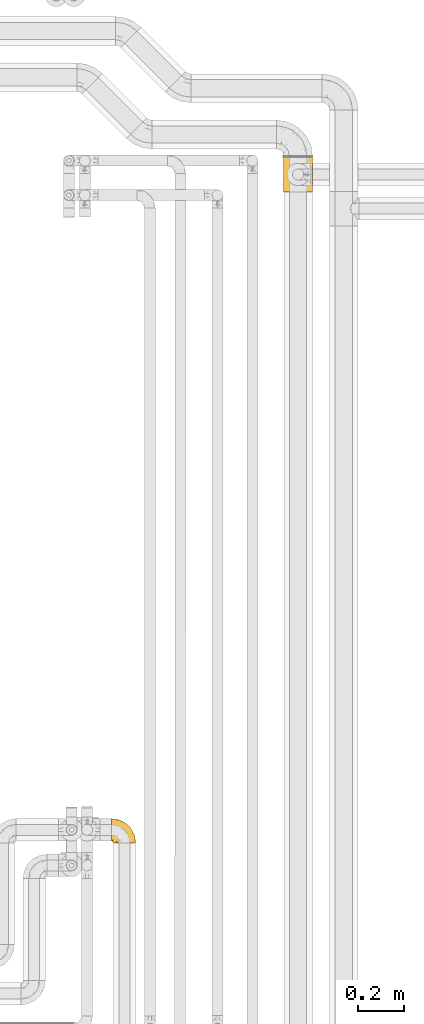
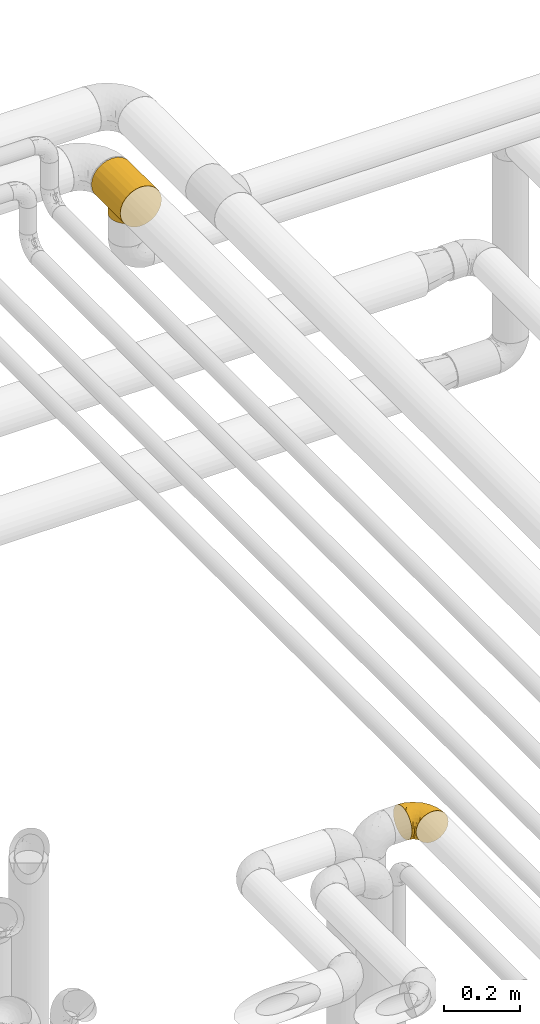
# One storey, part 403 of 827: 2 coverings.
"""IFC2X3 building model written with IfcOpenShell, lengths in millimetres."""

from ifc_helpers import new_model, entity, si_unit, converted_unit, derived_unit, direction, frame, origin, place, context, subcontext, project, spatial, faceted_brep, element, save


model = new_model("IFC2X3")

# Units and contexts
model_context = context("Model", 3, precision=0.01, world=origin(), true_north=direction((6.12303176911189e-17, 1.0)))
body_context = subcontext(model_context, "Body", "Model", "MODEL_VIEW")
ifc_project = project(units=[si_unit("LENGTHUNIT", "METRE", prefix="MILLI"), si_unit("AREAUNIT", "SQUARE_METRE"), si_unit("VOLUMEUNIT", "CUBIC_METRE"), converted_unit("PLANEANGLEUNIT", "DEGREE", entity("IfcRatioMeasure", 0.0174532925199433), si_unit("PLANEANGLEUNIT", "RADIAN"), dimensions=[0, 0, 0, 0, 0, 0, 0]), si_unit("MASSUNIT", "GRAM", prefix="KILO"), derived_unit("MASSDENSITYUNIT", [(si_unit("MASSUNIT", "GRAM", prefix="KILO"), 1), (si_unit("LENGTHUNIT", "METRE"), -3)]), derived_unit("MOMENTOFINERTIAUNIT", [(si_unit("LENGTHUNIT", "METRE"), 4)]), si_unit("TIMEUNIT", "SECOND"), si_unit("FREQUENCYUNIT", "HERTZ"), si_unit("THERMODYNAMICTEMPERATUREUNIT", "DEGREE_CELSIUS"), derived_unit("THERMALTRANSMITTANCEUNIT", [(si_unit("MASSUNIT", "GRAM", prefix="KILO"), 1), (si_unit("THERMODYNAMICTEMPERATUREUNIT", "KELVIN"), -1), (si_unit("TIMEUNIT", "SECOND"), -3)]), derived_unit("VOLUMETRICFLOWRATEUNIT", [(si_unit("LENGTHUNIT", "METRE"), 3), (si_unit("TIMEUNIT", "SECOND"), -1)]), derived_unit("MASSFLOWRATEUNIT", [(si_unit("MASSUNIT", "GRAM", prefix="KILO"), 1), (si_unit("TIMEUNIT", "SECOND"), -1)]), derived_unit("ROTATIONALFREQUENCYUNIT", [(si_unit("TIMEUNIT", "SECOND"), -1)]), si_unit("ELECTRICCURRENTUNIT", "AMPERE"), si_unit("ELECTRICVOLTAGEUNIT", "VOLT"), si_unit("POWERUNIT", "WATT"), si_unit("FORCEUNIT", "NEWTON", prefix="KILO"), si_unit("ILLUMINANCEUNIT", "LUX"), si_unit("LUMINOUSFLUXUNIT", "LUMEN"), si_unit("LUMINOUSINTENSITYUNIT", "CANDELA"), derived_unit("USERDEFINED", [(si_unit("MASSUNIT", "GRAM", prefix="KILO"), -1), (si_unit("LENGTHUNIT", "METRE"), -2), (si_unit("TIMEUNIT", "SECOND"), 3), (si_unit("LUMINOUSFLUXUNIT", "LUMEN"), 1)]), derived_unit("LINEARVELOCITYUNIT", [(si_unit("LENGTHUNIT", "METRE"), 1), (si_unit("TIMEUNIT", "SECOND"), -1)]), si_unit("PRESSUREUNIT", "PASCAL"), derived_unit("USERDEFINED", [(si_unit("LENGTHUNIT", "METRE"), -2), (si_unit("MASSUNIT", "GRAM", prefix="KILO"), 1), (si_unit("TIMEUNIT", "SECOND"), -2)]), derived_unit("LINEARFORCEUNIT", [(si_unit("MASSUNIT", "GRAM", prefix="KILO"), 1), (si_unit("LENGTHUNIT", "METRE"), 1), (si_unit("TIMEUNIT", "SECOND"), -2), (si_unit("LENGTHUNIT", "METRE"), -1)]), derived_unit("PLANARFORCEUNIT", [(si_unit("MASSUNIT", "GRAM", prefix="KILO"), 1), (si_unit("LENGTHUNIT", "METRE"), 1), (si_unit("TIMEUNIT", "SECOND"), -2), (si_unit("LENGTHUNIT", "METRE"), -2)])], contexts=[model_context])

# Site, building, storey
site_placement = place(None, origin())
site = spatial("IfcSite", under=ifc_project, at=site_placement, CompositionType="ELEMENT")
building_placement = place(site_placement, origin())
building = spatial("IfcBuilding", under=site, at=building_placement, CompositionType="ELEMENT")
storey_placement = place(building_placement, frame((0.0, 0.0, 28200.0)))
storey = spatial("IfcBuildingStorey", under=building, at=storey_placement, Name="08", CompositionType="ELEMENT", Elevation=28200.0)

# Coverings
covering_1_placement = place(storey_placement, frame((47825.42, 15248.43, 2949.25)))
element("IfcCovering", 1, at=covering_1_placement, inside=storey, Name=":ADSK_", ObjectType=":ADSK_", PredefinedType="INSULATION", context=body_context, shape_type="Brep", body=[
    faceted_brep([(1.6, 58.6, 99.9), (1.6, 69.54, 98.66), (1.6, 79.93, 95.02), (1.6, 89.25, 89.17), (1.6, 97.03, 81.38), (1.6, 102.88, 72.06), (1.6, 106.51, 61.68), (1.6, 107.75, 50.75), (1.6, 106.51, 39.8), (1.6, 102.87, 29.41), (1.6, 97.02, 20.09), (1.6, 89.23, 12.31), (1.6, 79.91, 6.46), (1.6, 69.53, 2.83), (1.6, 58.6, 1.6), (1.6, 52.89, 2.24), (1.6, 47.65, 2.83), (1.6, 42.46, 4.65), (1.6, 37.26, 6.47), (1.6, 27.94, 12.32), (1.6, 20.16, 20.11), (1.6, 14.31, 29.43), (1.6, 10.68, 39.81), (1.6, 9.45, 50.75), (1.6, 10.68, 61.69), (1.6, 14.32, 72.08), (1.6, 20.17, 81.4), (1.6, 27.96, 89.18), (1.6, 37.28, 95.03), (1.6, 42.47, 96.85), (1.6, 47.66, 98.66), (1.6, 52.89, 99.25), (1.6, 55.75, 99.57), (11.12, 1.6, 38.02), (16.03, 1.6, 26.17), (19.94, 1.6, 21.08), (23.84, 1.6, 15.99), (28.93, 1.6, 12.09), (34.02, 1.6, 8.18), (39.95, 1.6, 5.73), (45.87, 1.6, 3.27), (52.86, 1.6, 2.35), (55.73, 1.6, 1.97), (58.6, 1.6, 1.6), (71.32, 1.6, 3.27), (83.17, 1.6, 8.18), (93.35, 1.6, 15.99), (101.16, 1.6, 26.17), (106.07, 1.6, 38.02), (107.75, 1.6, 50.75), (106.07, 1.6, 63.47), (101.16, 1.6, 75.32), (93.35, 1.6, 85.5), (83.17, 1.6, 93.31), (71.32, 1.6, 98.22), (58.6, 1.6, 99.9), (52.86, 1.6, 99.14), (45.87, 1.6, 98.22), (39.95, 1.6, 95.77), (34.02, 1.6, 93.31), (28.93, 1.6, 89.4), (23.84, 1.6, 85.5), (19.94, 1.6, 80.41), (16.03, 1.6, 75.32), (11.12, 1.6, 63.47), (9.45, 1.6, 50.75), (81.82, 69.96, 59.31), (84.02, 59.59, 73.08), (93.05, 51.96, 63.72), (102.55, 34.4, 50.75), (104.83, 23.37, 58.64), (105.83, 13.68, 50.75), (91.87, 41.52, 76.74), (101.74, 26.26, 67.68), (97.07, 20.18, 78.92), (38.45, 72.33, 94.31), (22.17, 65.88, 98.76), (42.04, 57.55, 98.4), (77.69, 23.76, 94.57), (75.76, 46.5, 89.91), (62.11, 46.57, 96.32), (66.08, 21.17, 98.79), (54.26, 23.41, 99.9), (55.35, 17.92, 99.9), (56.44, 12.43, 99.9), (56.98, 9.72, 99.9), (57.52, 7.01, 99.9), (87.84, 26.77, 87.31), (19.41, 76.59, 95.61), (48.89, 95.55, 60.43), (26.34, 102.57, 65.24), (44.55, 92.89, 72.87), (23.41, 54.26, 99.9), (28.03, 51.17, 99.9), (32.65, 48.08, 99.9), (37.28, 44.99, 99.9), (41.9, 41.9, 99.9), (20.6, 85.16, 90.65), (63.36, 85.97, 63.14), (62.21, 59.58, 91.89), (19.94, 99.5, 75.25), (13.68, 105.83, 50.75), (80.85, 53.59, 82.18), (66.53, 67.0, 85.08), (71.06, 71.56, 76.93), (63.99, 87.47, 50.75), (75.73, 75.73, 50.75), (26.77, 92.24, 83.02), (4.31, 58.06, 99.9), (7.01, 57.52, 99.9), (12.43, 56.44, 99.9), (17.92, 55.35, 99.9), (43.43, 81.33, 87.13), (56.23, 80.35, 80.85), (54.97, 39.44, 99.17), (34.4, 102.55, 50.75), (44.99, 37.28, 99.9), (48.08, 32.65, 99.9), (51.17, 28.03, 99.9), (87.47, 63.99, 50.75), (74.55, 74.55, 67.61), (60.86, 83.62, 72.25), (49.19, 95.01, 50.75), (95.01, 49.19, 50.75), (10.27, 46.96, 98.69), (48.79, 8.77, 99.01), (45.16, 18.28, 98.79), (44.99, 11.68, 98.29), (6.17, 11.79, 68.51), (7.65, 15.69, 76.82), (21.59, 42.49, 98.54), (19.96, 47.41, 99.3), (21.0, 7.94, 83.57), (27.2, 9.27, 89.47), (14.83, 7.98, 75.76), (19.7, 13.4, 84.86), (10.93, 13.04, 75.89), (9.63, 7.36, 64.77), (19.97, 23.46, 90.83), (21.13, 30.46, 94.62), (14.14, 26.54, 90.37), (30.2, 6.76, 91.18), (8.12, 26.46, 88.65), (9.93, 20.77, 84.11), (24.62, 20.68, 91.75), (11.87, 40.26, 96.86), (7.15, 7.15, 50.75), (5.32, 9.28, 58.97), (26.68, 38.78, 98.37), (13.92, 18.27, 83.91), (30.67, 31.78, 97.52), (36.65, 12.75, 95.55), (42.89, 22.96, 98.76), (34.04, 17.55, 95.26), (36.6, 27.63, 98.04), (26.41, 15.23, 90.65), (10.07, 33.25, 93.51), (15.83, 32.43, 94.16), (41.99, 27.9, 99.1), (14.83, 7.97, 25.73), (26.4, 15.22, 10.84), (21.01, 7.93, 17.92), (19.71, 13.38, 16.64), (5.72, 13.12, 30.44), (21.6, 42.49, 2.95), (19.96, 47.4, 2.19), (28.03, 51.17, 1.6), (11.87, 40.24, 4.63), (9.93, 20.76, 17.39), (58.06, 4.31, 1.6), (56.44, 12.43, 1.6), (57.52, 7.01, 1.6), (8.13, 26.44, 12.86), (14.15, 26.52, 11.13), (44.99, 11.68, 3.2), (36.65, 12.75, 5.94), (30.2, 6.76, 10.31), (10.06, 33.21, 8.0), (15.83, 32.41, 7.34), (48.79, 8.77, 2.48), (42.89, 22.96, 2.73), (45.38, 18.48, 2.64), (12.43, 56.44, 1.6), (10.28, 46.95, 2.8), (9.64, 7.36, 36.71), (55.35, 17.92, 1.6), (54.26, 23.41, 1.6), (6.05, 9.85, 38.59), (7.01, 57.52, 1.6), (9.72, 56.98, 1.6), (32.65, 48.08, 1.6), (26.68, 38.78, 3.12), (13.92, 18.25, 17.59), (37.28, 44.99, 1.6), (30.66, 31.74, 3.98), (21.14, 30.45, 6.87), (36.59, 27.63, 3.45), (24.6, 20.65, 9.76), (17.92, 55.35, 1.6), (23.41, 54.26, 1.6), (10.93, 13.03, 25.62), (19.97, 23.44, 10.67), (41.99, 27.9, 2.39), (48.08, 32.65, 1.6), (34.04, 17.55, 6.23), (27.21, 9.27, 12.02), (51.17, 28.03, 1.6), (44.99, 37.28, 1.6), (41.9, 41.9, 1.6), (55.26, 39.74, 2.4), (104.83, 23.37, 42.85), (87.84, 26.77, 14.18), (75.91, 46.18, 11.56), (80.84, 53.54, 19.27), (91.87, 41.53, 24.75), (83.98, 59.61, 28.37), (19.16, 76.79, 5.95), (22.37, 66.11, 2.79), (66.08, 21.17, 2.71), (93.05, 51.96, 37.78), (101.74, 26.26, 33.81), (97.07, 20.18, 22.57), (77.69, 23.76, 6.92), (44.55, 92.88, 28.61), (26.34, 102.57, 36.24), (48.9, 95.54, 41.05), (70.99, 71.63, 24.55), (74.55, 74.55, 33.88), (37.8, 72.51, 7.11), (81.82, 69.96, 42.18), (26.77, 92.23, 18.46), (20.6, 85.15, 10.84), (56.15, 80.45, 20.69), (60.85, 83.65, 29.27), (42.06, 57.57, 3.1), (57.03, 63.68, 9.18), (63.4, 85.95, 38.38), (19.94, 99.49, 26.23), (43.59, 81.23, 14.34), (62.61, 47.07, 5.46), (66.52, 66.99, 16.39)], [[[0, 1, 2, 3, 4, 5, 6, 7, 8, 9, 10, 11, 12, 13, 14, 15, 16, 17, 18, 19, 20, 21, 22, 23, 24, 25, 26, 27, 28, 29, 30, 31, 32]], [[33, 34, 35, 36, 37, 38, 39, 40, 41, 42, 43, 44, 45, 46, 47, 48, 49, 50, 51, 52, 53, 54, 55, 56, 57, 58, 59, 60, 61, 62, 63, 64, 65]], [[66, 67, 68]], [[69, 70, 71]], [[68, 72, 73]], [[73, 72, 74]], [[75, 76, 77]], [[78, 79, 80]], [[51, 50, 73]], [[81, 82, 83, 84, 85, 86, 55]], [[52, 87, 53]], [[74, 52, 51]], [[2, 1, 88]], [[89, 90, 91]], [[77, 92, 93, 94, 95, 96]], [[55, 54, 81]], [[78, 53, 87]], [[5, 90, 6]], [[88, 76, 75]], [[97, 3, 2]], [[89, 91, 98]], [[99, 80, 79]], [[90, 5, 100]], [[74, 87, 52]], [[100, 5, 4]], [[90, 101, 6]], [[79, 102, 103]], [[102, 67, 104]], [[105, 98, 106]], [[107, 4, 3]], [[76, 0, 108, 109, 110, 111, 92]], [[107, 112, 113]], [[114, 77, 96]], [[89, 115, 90]], [[114, 96, 116, 117, 118, 82]], [[75, 97, 88]], [[119, 66, 68]], [[50, 71, 70]], [[100, 91, 90]], [[99, 77, 80]], [[102, 104, 103]], [[97, 107, 3]], [[80, 81, 78]], [[107, 97, 112]], [[68, 73, 70]], [[66, 98, 120]], [[78, 81, 54]], [[114, 81, 80]], [[53, 78, 54]], [[78, 87, 79]], [[102, 87, 72]], [[79, 103, 99]], [[4, 107, 100]], [[91, 100, 107]], [[88, 97, 2]], [[112, 97, 75]], [[99, 112, 75]], [[103, 104, 113]], [[91, 121, 98]], [[89, 105, 122, 115]], [[101, 90, 115]], [[101, 7, 6]], [[88, 1, 76]], [[0, 76, 1]], [[92, 77, 76]], [[73, 74, 51]], [[87, 74, 72]], [[81, 114, 82]], [[77, 114, 80]], [[87, 102, 79]], [[67, 102, 72]], [[68, 67, 72]], [[67, 120, 104]], [[120, 121, 104]], [[104, 121, 113]], [[121, 120, 98]], [[91, 107, 113]], [[91, 113, 121]], [[103, 113, 112]], [[106, 98, 66]], [[105, 89, 98]], [[106, 66, 119]], [[67, 66, 120]], [[68, 69, 123, 119]], [[50, 49, 71]], [[50, 70, 73]], [[112, 99, 103]], [[77, 99, 75]], [[69, 68, 70]], [[29, 124, 110]], [[84, 83, 125]], [[126, 82, 118]], [[59, 58, 127]], [[25, 128, 129]], [[130, 93, 131]], [[132, 62, 133]], [[134, 135, 136]], [[137, 65, 64]], [[64, 134, 137]], [[138, 139, 140]], [[111, 110, 124, 92]], [[134, 136, 137]], [[134, 64, 63]], [[141, 61, 60]], [[125, 58, 57]], [[142, 143, 140]], [[142, 26, 143]], [[127, 83, 82]], [[28, 124, 29]], [[32, 31, 30, 110, 109, 108, 0]], [[30, 29, 110]], [[135, 144, 138]], [[28, 145, 124]], [[57, 56, 55, 86, 85, 84]], [[146, 147, 23]], [[24, 23, 147]], [[25, 143, 26]], [[95, 94, 148]], [[24, 128, 25]], [[149, 138, 143]], [[124, 145, 131]], [[127, 58, 125]], [[150, 148, 139]], [[127, 126, 151]], [[151, 59, 127]], [[152, 151, 126]], [[153, 154, 155]], [[153, 133, 141]], [[145, 28, 27]], [[142, 156, 27]], [[157, 148, 130]], [[61, 133, 62]], [[134, 132, 135]], [[147, 128, 24]], [[65, 137, 146]], [[146, 137, 147]], [[128, 137, 136]], [[137, 128, 147]], [[128, 136, 129]], [[149, 129, 136]], [[25, 129, 143]], [[158, 152, 117]], [[152, 118, 117]], [[153, 151, 152]], [[158, 116, 154]], [[144, 150, 138]], [[153, 152, 158]], [[133, 153, 155]], [[133, 155, 132]], [[141, 60, 151]], [[135, 132, 155]], [[134, 63, 132]], [[144, 135, 155]], [[135, 138, 149]], [[155, 154, 144]], [[150, 154, 96]], [[154, 150, 144]], [[148, 94, 130]], [[82, 126, 127]], [[118, 152, 126]], [[150, 96, 95]], [[139, 148, 157]], [[150, 95, 148]], [[93, 92, 131]], [[130, 145, 156]], [[130, 94, 93]], [[84, 125, 57]], [[127, 125, 83]], [[140, 139, 157]], [[150, 139, 138]], [[140, 157, 142]], [[138, 140, 143]], [[156, 142, 157]], [[27, 26, 142]], [[130, 156, 157]], [[145, 27, 156]], [[132, 63, 62]], [[124, 131, 92]], [[130, 131, 145]], [[129, 149, 143]], [[135, 149, 136]], [[153, 141, 151]], [[59, 151, 60]], [[133, 61, 141]], [[116, 96, 154]], [[153, 158, 154]], [[158, 117, 116]], [[34, 33, 159]], [[160, 161, 162]], [[22, 21, 163]], [[164, 165, 166]], [[19, 18, 167]], [[168, 21, 20]], [[169, 43, 42, 41, 40, 170, 171]], [[172, 173, 168]], [[174, 38, 175]], [[37, 36, 176]], [[177, 164, 178]], [[40, 179, 170]], [[180, 181, 175]], [[17, 182, 183]], [[65, 146, 184]], [[185, 174, 186]], [[23, 22, 187]], [[174, 39, 38]], [[15, 14, 188, 189, 182, 16]], [[179, 40, 39]], [[190, 191, 164]], [[192, 163, 168]], [[33, 184, 159]], [[178, 173, 172]], [[193, 194, 191]], [[18, 183, 167]], [[173, 178, 195]], [[196, 197, 194]], [[198, 199, 183, 182]], [[182, 17, 16]], [[18, 17, 183]], [[200, 159, 184]], [[192, 168, 201]], [[187, 163, 200]], [[202, 203, 180]], [[185, 179, 174]], [[160, 204, 205]], [[206, 181, 180]], [[206, 180, 203]], [[199, 165, 183]], [[165, 164, 167]], [[172, 177, 178]], [[200, 192, 162]], [[205, 161, 160]], [[65, 184, 33]], [[163, 187, 22]], [[175, 204, 180]], [[174, 181, 186]], [[204, 196, 202]], [[197, 160, 162]], [[196, 207, 202]], [[37, 176, 175]], [[196, 204, 160]], [[176, 204, 175]], [[205, 35, 161]], [[34, 159, 161]], [[162, 161, 159]], [[200, 162, 159]], [[197, 162, 201]], [[194, 197, 201]], [[196, 160, 197]], [[191, 195, 178]], [[208, 196, 194]], [[186, 181, 206]], [[175, 181, 174]], [[191, 190, 193]], [[193, 208, 194]], [[195, 194, 201]], [[178, 164, 191]], [[168, 163, 21]], [[166, 165, 199]], [[166, 190, 164]], [[187, 200, 184]], [[184, 146, 187]], [[23, 187, 146]], [[174, 179, 39]], [[170, 179, 185]], [[194, 195, 191]], [[173, 201, 168]], [[201, 173, 195]], [[172, 168, 20]], [[20, 19, 172]], [[177, 172, 19]], [[19, 167, 177]], [[164, 177, 167]], [[35, 205, 36]], [[35, 34, 161]], [[183, 165, 167]], [[162, 192, 201]], [[163, 192, 200]], [[175, 38, 37]], [[36, 205, 176]], [[204, 176, 205]], [[204, 202, 180]], [[207, 196, 208]], [[207, 203, 202]], [[209, 186, 206, 203, 207, 208]], [[48, 210, 71]], [[211, 212, 213]], [[214, 213, 215]], [[216, 217, 13]], [[218, 43, 169, 171, 170, 185, 186]], [[219, 220, 214]], [[47, 46, 221]], [[210, 48, 220]], [[211, 222, 212]], [[222, 45, 44]], [[221, 220, 47]], [[47, 220, 48]], [[221, 211, 214]], [[223, 224, 225]], [[211, 46, 45]], [[226, 227, 215]], [[43, 218, 44]], [[217, 216, 228]], [[215, 229, 219]], [[14, 13, 217]], [[224, 9, 8]], [[10, 230, 11]], [[11, 231, 12]], [[232, 223, 233]], [[234, 208, 193, 190, 166, 199]], [[235, 234, 228]], [[222, 44, 218]], [[106, 229, 236]], [[224, 237, 9]], [[231, 238, 228]], [[9, 237, 10]], [[115, 224, 101]], [[239, 234, 235]], [[231, 11, 230]], [[223, 230, 237]], [[224, 8, 101]], [[223, 236, 233]], [[225, 115, 122, 105]], [[216, 12, 231]], [[209, 234, 239]], [[210, 219, 69]], [[219, 214, 215]], [[229, 119, 219]], [[209, 218, 186]], [[239, 212, 222]], [[239, 222, 218]], [[45, 222, 211]], [[235, 212, 239]], [[213, 212, 240]], [[223, 237, 224]], [[230, 10, 237]], [[238, 231, 230]], [[216, 231, 228]], [[232, 230, 223]], [[235, 238, 240]], [[115, 225, 224]], [[233, 236, 227]], [[8, 7, 101]], [[234, 209, 208]], [[218, 209, 239]], [[217, 228, 234]], [[13, 12, 216]], [[234, 199, 217]], [[217, 199, 198, 182, 189, 188, 14]], [[211, 221, 46]], [[220, 221, 214]], [[71, 210, 69]], [[71, 49, 48]], [[219, 210, 220]], [[226, 215, 213]], [[211, 213, 214]], [[226, 213, 240]], [[215, 227, 229]], [[232, 240, 238]], [[233, 227, 226]], [[232, 233, 226]], [[236, 223, 225]], [[240, 232, 226]], [[232, 238, 230]], [[225, 105, 236]], [[236, 105, 106]], [[229, 106, 119]], [[69, 219, 119, 123]], [[236, 229, 227]], [[238, 235, 228]], [[212, 235, 240]]]),
])
covering_2_placement = place(storey_placement, frame((48580.2, 18104.53, 2933.0)))
element("IfcCovering", 2, at=covering_2_placement, inside=storey, Name=":ADSK_", ObjectType=":ADSK_", PredefinedType="INSULATION", context=body_context, shape_type="Brep", body=[
    faceted_brep([(33.12, 152.0, 121.6), (48.33, 152.0, 127.9), (64.65, 152.0, 130.05), (80.96, 152.0, 127.9), (96.17, 152.0, 121.6), (109.23, 152.0, 111.58), (119.25, 152.0, 98.53), (125.55, 152.0, 83.32), (127.7, 152.0, 67.0), (125.55, 152.0, 50.68), (119.25, 152.0, 35.48), (109.23, 152.0, 22.42), (102.7, 152.0, 17.41), (96.17, 152.0, 12.4), (88.57, 152.0, 9.25), (80.96, 152.0, 6.1), (72.8, 152.0, 5.02), (64.65, 152.0, 3.95), (56.49, 152.0, 5.02), (48.33, 152.0, 6.1), (40.72, 152.0, 9.25), (33.12, 152.0, 12.4), (26.59, 152.0, 17.41), (20.06, 152.0, 22.42), (10.04, 152.0, 35.47), (3.74, 152.0, 50.68), (1.6, 152.0, 67.0), (3.74, 152.0, 83.32), (10.04, 152.0, 98.53), (20.06, 152.0, 111.58), (127.7, 0.0, 67.0), (125.55, 0.0, 83.32), (119.25, 0.0, 98.53), (109.23, 0.0, 111.58), (96.17, 0.0, 121.6), (80.96, 0.0, 127.9), (64.65, 0.0, 130.05), (48.33, 0.0, 127.9), (33.12, 0.0, 121.6), (20.06, 0.0, 111.58), (10.04, 0.0, 98.53), (3.74, 0.0, 83.32), (1.6, 0.0, 67.0), (3.74, 0.0, 50.68), (10.04, 0.0, 35.47), (20.06, 0.0, 22.42), (26.59, 0.0, 17.41), (33.12, 0.0, 12.4), (40.72, 0.0, 9.25), (48.33, 0.0, 6.1), (56.49, 0.0, 5.02), (64.65, 0.0, 3.95), (72.8, 0.0, 5.02), (80.96, 0.0, 6.1), (88.57, 0.0, 9.25), (96.17, 0.0, 12.4), (102.7, 0.0, 17.41), (109.23, 0.0, 22.42), (119.25, 0.0, 35.48), (125.55, 0.0, 50.68), (103.13, 45.43, 17.06), (108.76, 54.33, 21.96), (95.74, 37.94, 12.15), (86.67, 119.94, 7.92), (112.46, 64.61, 25.9), (113.8, 76.0, 27.51), (112.46, 87.39, 25.9), (70.38, 124.47, 4.48), (64.65, 125.15, 3.95), (64.65, 26.85, 3.95), (70.38, 27.53, 4.48), (103.13, 106.57, 17.06), (108.76, 97.67, 21.96), (95.74, 114.06, 12.15), (86.67, 32.06, 7.92), (81.39, 121.87, 6.46), (76.12, 123.79, 5.0), (76.12, 28.21, 5.0), (81.39, 30.13, 6.46), (58.91, 27.53, 4.48), (53.17, 28.21, 5.0), (33.55, 37.94, 12.15), (42.62, 32.06, 7.92), (47.9, 30.13, 6.46), (53.17, 123.79, 5.0), (58.91, 124.47, 4.48), (33.55, 114.06, 12.15), (42.62, 119.94, 7.92), (26.16, 106.57, 17.06), (47.9, 121.87, 6.46), (26.16, 45.43, 17.06), (20.53, 54.33, 21.96), (16.83, 64.61, 25.9), (15.5, 76.0, 27.51), (20.53, 97.67, 21.96), (16.83, 87.39, 25.9), (112.12, 63.28, 0.0), (107.21, 51.42, 0.0), (99.4, 41.25, 0.0), (89.22, 33.43, 0.0), (83.29, 30.98, 0.0), (77.37, 28.52, 0.0), (71.01, 27.69, 0.0), (64.65, 26.85, 0.0), (58.28, 27.69, 0.0), (51.92, 28.52, 0.0), (46.0, 30.98, 0.0), (40.07, 33.43, 0.0), (29.89, 41.25, 0.0), (22.08, 51.42, 0.0), (17.17, 63.28, 0.0), (15.5, 76.0, 0.0), (17.17, 88.72, 0.0), (22.08, 100.57, 0.0), (29.89, 110.75, 0.0), (40.07, 118.57, 0.0), (46.0, 121.02, 0.0), (51.92, 123.48, 0.0), (58.28, 124.31, 0.0), (64.65, 125.15, 0.0), (71.01, 124.31, 0.0), (77.37, 123.48, 0.0), (83.29, 121.02, 0.0), (89.22, 118.57, 0.0), (99.4, 110.75, 0.0), (107.21, 100.57, 0.0), (112.12, 88.72, 0.0), (113.8, 76.0, 0.0)], [[[0, 1, 2, 3, 4, 5, 6, 7, 8, 9, 10, 11, 12, 13, 14, 15, 16, 17, 18, 19, 20, 21, 22, 23, 24, 25, 26, 27, 28, 29]], [[30, 31, 32, 33, 34, 35, 36, 37, 38, 39, 40, 41, 42, 43, 44, 45, 46, 47, 48, 49, 50, 51, 52, 53, 54, 55, 56, 57, 58, 59]], [[34, 33, 5, 4]], [[2, 36, 35, 3]], [[4, 3, 35, 34]], [[6, 32, 31, 7]], [[7, 31, 30, 8]], [[5, 33, 32, 6]], [[59, 9, 8, 30]], [[58, 10, 9, 59]], [[57, 60, 61]], [[56, 55, 62]], [[63, 15, 14]], [[61, 64, 57]], [[60, 57, 56]], [[57, 64, 58]], [[64, 65, 58]], [[66, 11, 10]], [[17, 67, 68]], [[69, 70, 51]], [[71, 11, 72]], [[72, 11, 66]], [[73, 12, 71]], [[66, 10, 65]], [[65, 10, 58]], [[62, 54, 74]], [[54, 62, 55]], [[74, 54, 53]], [[15, 63, 75, 76]], [[77, 53, 52]], [[51, 70, 52]], [[77, 52, 70]], [[53, 77, 78, 74]], [[73, 13, 12]], [[73, 14, 13]], [[14, 73, 63]], [[16, 76, 67]], [[71, 12, 11]], [[17, 16, 67]], [[16, 15, 76]], [[60, 56, 62]], [[50, 79, 51]], [[80, 50, 49]], [[47, 81, 48]], [[82, 48, 81]], [[82, 49, 48]], [[49, 82, 83, 80]], [[50, 80, 79]], [[84, 18, 85]], [[85, 17, 68]], [[51, 79, 69]], [[86, 21, 20]], [[17, 85, 18]], [[20, 19, 87]], [[86, 88, 22]], [[87, 19, 84, 89]], [[81, 46, 90]], [[81, 47, 46]], [[90, 45, 91]], [[45, 90, 46]], [[91, 45, 92]], [[24, 44, 43, 25]], [[93, 92, 44]], [[44, 92, 45]], [[43, 42, 26, 25]], [[84, 19, 18]], [[94, 95, 23]], [[86, 20, 87]], [[22, 21, 86]], [[23, 88, 94]], [[95, 24, 23]], [[93, 24, 95]], [[93, 44, 24]], [[88, 23, 22]], [[27, 41, 40, 28]], [[28, 40, 39, 29]], [[42, 41, 27, 26]], [[0, 38, 37, 1]], [[1, 37, 36, 2]], [[29, 39, 38, 0]], [[96, 97, 98, 99, 100, 101, 102, 103, 104, 105, 106, 107, 108, 109, 110, 111, 112, 113, 114, 115, 116, 117, 118, 119, 120, 121, 122, 123, 124, 125, 126, 127]], [[77, 102, 101]], [[74, 100, 99]], [[103, 70, 69]], [[103, 102, 70]], [[101, 78, 77]], [[62, 74, 99]], [[100, 78, 101]], [[100, 74, 78]], [[99, 98, 62]], [[60, 98, 97]], [[96, 127, 64]], [[102, 77, 70]], [[61, 97, 96]], [[60, 97, 61]], [[64, 61, 96]], [[65, 64, 127]], [[98, 60, 62]], [[66, 127, 126]], [[72, 126, 125]], [[65, 127, 66]], [[119, 67, 120]], [[66, 126, 72]], [[125, 71, 72]], [[125, 124, 71]], [[73, 124, 123]], [[76, 75, 121]], [[67, 119, 68]], [[76, 121, 120]], [[63, 73, 123]], [[63, 123, 122]], [[76, 120, 67]], [[122, 75, 63]], [[121, 75, 122]], [[124, 73, 71]], [[84, 118, 117]], [[87, 116, 115]], [[119, 85, 68]], [[119, 118, 85]], [[117, 89, 84]], [[86, 87, 115]], [[116, 89, 117]], [[118, 84, 85]], [[115, 114, 86]], [[88, 114, 113]], [[113, 112, 94]], [[111, 95, 112]], [[116, 87, 89]], [[88, 113, 94]], [[95, 94, 112]], [[93, 95, 111]], [[114, 88, 86]], [[92, 111, 110]], [[91, 110, 109]], [[93, 111, 92]], [[103, 79, 104]], [[92, 110, 91]], [[109, 90, 91]], [[109, 108, 90]], [[81, 108, 107]], [[80, 83, 105]], [[79, 103, 69]], [[80, 105, 104]], [[82, 81, 107]], [[82, 107, 106]], [[80, 104, 79]], [[106, 83, 82]], [[105, 83, 106]], [[108, 81, 90]]]),
])

save(model, "model.ifc")
